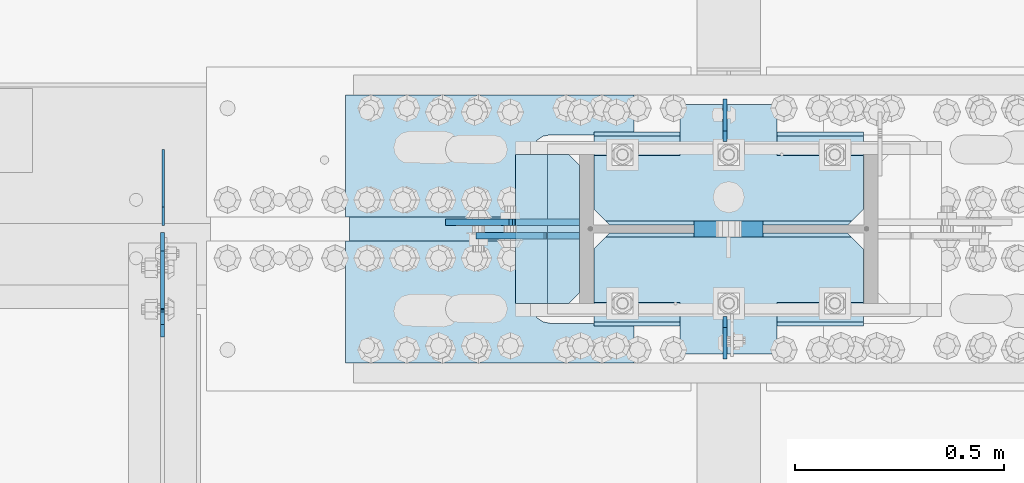
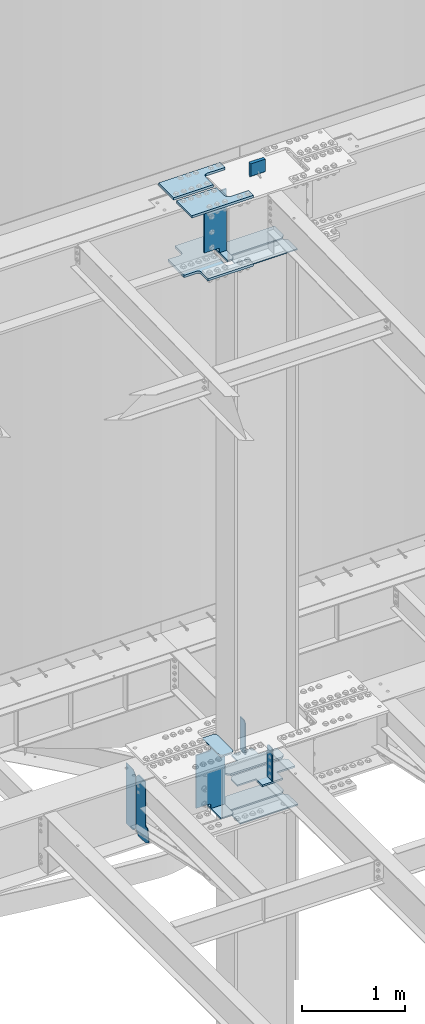
# One storey, part 1625 of 1763: 19 plates, 5 elements without a shape of their own.
"""IFC2X3 building model written with IfcOpenShell, lengths in millimetres."""

from ifc_helpers import new_model, si_unit, frame, origin_with_axes, place, context, subcontext, project, spatial, faceted_brep, material, type_object, element, aggregate, save


model = new_model("IFC2X3")

# Units and contexts
model_context = context("Model", 3, precision=1e-05, world=origin_with_axes())
body_context = subcontext(model_context, "Body", "Model", "MODEL_VIEW")
ifc_project = project(units=[si_unit("LENGTHUNIT", "METRE", prefix="MILLI"), si_unit("AREAUNIT", "SQUARE_METRE"), si_unit("VOLUMEUNIT", "CUBIC_METRE"), si_unit("MASSUNIT", "GRAM", prefix="KILO"), si_unit("TIMEUNIT", "SECOND"), si_unit("PLANEANGLEUNIT", "RADIAN"), si_unit("SOLIDANGLEUNIT", "STERADIAN"), si_unit("THERMODYNAMICTEMPERATUREUNIT", "DEGREE_CELSIUS"), si_unit("LUMINOUSINTENSITYUNIT", "LUMEN")], contexts=[model_context])

# Site, building, storey
site_placement = place(None, origin_with_axes())
site = spatial("IfcSite", under=ifc_project, at=site_placement, CompositionType="ELEMENT")
building_placement = place(site_placement, origin_with_axes())
building = spatial("IfcBuilding", under=site, at=building_placement, Name="Undefined", CompositionType="ELEMENT")
storey_placement = place(building_placement, origin_with_axes())
storey = spatial("IfcBuildingStorey", under=building, at=storey_placement, Name="Undefined", CompositionType="ELEMENT", Elevation=0.0)

# Assembly, plates
assembly_1_placement = place(storey_placement, origin_with_axes())
assembly_1 = element("IfcElementAssembly", 1, at=assembly_1_placement, inside=storey, Name="COLUMN", AssemblyPlace="NOTDEFINED", PredefinedType="RIGID_FRAME")
ifc_material_1 = material(Name="STEEL/A572-GR.50")
plate_type_1 = type_object("IfcPlateType", PredefinedType="NOTDEFINED")
plate_1_placement = place(assembly_1_placement, frame((-49411.1685236983, 51911.25, 5165.725), z_axis=(0.0, -1.0, 0.0), x_axis=(0.0, 0.0, -1.0)))
plate_1 = element("IfcPlate", 2, at=plate_1_placement, type_object=plate_type_1, material=ifc_material_1, Name="PLATE", context=body_context, shape_type="Brep", body=[
    faceted_brep([(25.3999996185303, -4.76250000000073, 0.0), (0.0, -4.76250000000073, 25.3999996185303), (0.0, 4.76250000000073, 25.3999996185303), (25.3999996185303, 4.76250000000073, 0.0), (1.45519152283669e-11, -4.76250000000448, 101.60001373291), (390.524993896484, -4.76249999999709, 101.599998474121), (390.524993896484, 4.76249999999709, 101.599998474121), (0.0, 4.76250000000243, 101.60001373291), (390.524993896484, -4.76249999999709, 0.0), (390.524993896484, 4.76249999999709, 0.0)], [[[0, 1, 2, 3]], [[4, 5, 6, 7]], [[5, 8, 9, 6]], [[9, 8, 0, 3]], [[7, 6, 9, 3, 2]], [[4, 7, 2, 1]], [[8, 5, 4, 1, 0]]]),
])
plate_2_placement = place(assembly_1_placement, frame((-49411.1685236984, 52330.35, 5165.725), z_axis=(0.0, 1.0, 0.0), x_axis=(0.0, 0.0, -1.0)))
plate_2 = element("IfcPlate", 3, at=plate_2_placement, type_object=plate_type_1, material=ifc_material_1, Name="PLATE", context=body_context, shape_type="Brep", body=[
    faceted_brep([(25.3999996185303, -4.76250000000073, 0.0), (0.0, -4.76250000000073, 25.3999996185303), (0.0, 4.76250000000073, 25.3999996185303), (25.3999996185303, 4.76250000000073, 0.0), (1.45519152283669e-11, -4.76250000000448, 101.60001373291), (390.524993896484, -4.76249999999709, 101.599998474121), (390.524993896484, 4.76249999999709, 101.599998474121), (0.0, 4.76250000000243, 101.60001373291), (390.524993896484, -4.76249999999709, 0.0), (390.524993896484, 4.76249999999709, 0.0)], [[[0, 1, 2, 3]], [[4, 5, 6, 7]], [[5, 8, 9, 6]], [[9, 8, 0, 3]], [[7, 6, 9, 3, 2]], [[4, 7, 2, 1]], [[8, 5, 4, 1, 0]]]),
])

# Assembly, plate
assembly_2_placement = place(storey_placement, origin_with_axes())
assembly_2 = element("IfcElementAssembly", 4, at=assembly_2_placement, inside=storey, Name="BEAM", AssemblyPlace="NOTDEFINED", PredefinedType="RIGID_FRAME")
ifc_material_2 = material(Name="STEEL/A36")
plate_type_2 = type_object("IfcPlateType", PredefinedType="NOTDEFINED")
plate_3_placement = place(assembly_2_placement, frame((-50754.987273746, 52128.7375, 4448.175), z_axis=(0.0, 0.0, 1.0), x_axis=(0.0, 1.0, 0.0)))
plate_3 = element("IfcPlate", 5, at=plate_3_placement, type_object=plate_type_2, material=ifc_material_2, Name="PLATE", context=body_context, shape_type="Brep", body=[
    faceted_brep([(0.0, -3.17500000000291, 44.4500000000007), (0.0, -3.17500000000291, 673.099987030029), (0.0, 3.17500000000291, 673.099987030029), (0.0, 3.17500000000291, 44.4500000000007), (44.4500007629395, -3.17500000000291, 717.549987792969), (44.4500007629395, 3.17500000000291, 717.549987792969), (182.5625, -3.17500000000291, 717.549987792969), (182.5625, 3.17500000000291, 717.549987792969), (182.5625, -3.17500000000291, 0.0), (182.5625, 3.17500000000291, 0.0), (44.4500007629395, -3.17500000000291, 0.0), (44.4500007629395, 3.17500000000291, 0.0)], [[[0, 1, 2, 3]], [[1, 4, 5, 2]], [[4, 6, 7, 5]], [[6, 8, 9, 7]], [[8, 10, 11, 9]], [[10, 0, 3, 11]], [[5, 7, 9, 11, 3, 2]], [[10, 8, 6, 4, 1, 0]]]),
])

# Plate
ifc_material_3 = material(Name="STEEL/A572-50")
plate_type_3 = type_object("IfcPlateType", PredefinedType="NOTDEFINED")
plate_4_placement = place(assembly_1_placement, frame((-49912.0247736984, 52298.6, 4427.5375), z_axis=(1.0, 0.0, 0.0), x_axis=(0.0, -1.0, 0.0)))
plate_4 = element("IfcPlate", 6, at=plate_4_placement, type_object=plate_type_3, material=ifc_material_3, Name="PLATE", context=body_context, shape_type="Brep", body=[
    faceted_brep([(-7.27595761418343e-12, -7.9375, 0.0), (0.0, -7.9375, 126.999994277954), (0.0, 7.9375, 126.999994277954), (-7.27595761418343e-12, 7.9375, 0.0), (25.3999996185303, -7.9375, 152.399993896484), (25.3999996185303, 7.9375, 152.399993896484), (330.200006484985, -7.9375, 152.399993896484), (330.200006484985, 7.9375, 152.399993896484), (355.600006103516, -7.9375, 126.999994277954), (355.600006103516, 7.9375, 126.999994277954), (355.600006103516, -7.9375, 0.0), (355.600006103516, 7.9375, 0.0)], [[[0, 1, 2, 3]], [[1, 4, 5, 2]], [[4, 6, 7, 5]], [[6, 8, 9, 7]], [[8, 10, 11, 9]], [[10, 0, 3, 11]], [[5, 7, 9, 11, 3, 2]], [[10, 8, 6, 4, 1, 0]]]),
])

plate_5_placement = place(assembly_1_placement, frame((-49912.0247736984, 52298.6, 5157.7875), z_axis=(1.0, 0.0, 0.0), x_axis=(0.0, -1.0, 0.0)))
plate_5 = element("IfcPlate", 7, at=plate_5_placement, type_object=plate_type_3, material=ifc_material_3, Name="PLATE", context=body_context, shape_type="Brep", body=[
    faceted_brep([(-7.27595761418343e-12, -7.9375, 0.0), (0.0, -7.9375, 126.999994277954), (0.0, 7.9375, 126.999994277954), (-7.27595761418343e-12, 7.9375, 0.0), (25.3999996185303, -7.9375, 152.399993896484), (25.3999996185303, 7.9375, 152.399993896484), (330.200006484985, -7.9375, 152.399993896484), (330.200006484985, 7.9375, 152.399993896484), (355.600006103516, -7.9375, 126.999994277954), (355.600006103516, 7.9375, 126.999994277954), (355.600006103516, -7.9375, 0.0), (355.600006103516, 7.9375, 0.0)], [[[0, 1, 2, 3]], [[1, 4, 5, 2]], [[4, 6, 7, 5]], [[6, 8, 9, 7]], [[8, 10, 11, 9]], [[10, 0, 3, 11]], [[5, 7, 9, 11, 3, 2]], [[10, 8, 6, 4, 1, 0]]]),
])

plate_type_4 = type_object("IfcPlateType", PredefinedType="NOTDEFINED")
plate_6_placement = place(assembly_1_placement, frame((-49724.6997736983, 51889.025, 4335.4625), z_axis=(1.0, 0.0, 0.0), x_axis=(0.0, 1.0, 0.0)))
plate_6 = element("IfcPlate", 8, at=plate_6_placement, type_object=plate_type_4, material=ifc_material_3, Name="HORIZONTAL SHEAR PLAT", context=body_context, shape_type="Brep", body=[
    faceted_brep([(-7.27595761418343e-12, -7.9375, 0.0), (0.0, -7.9375, 644.524963378906), (0.0, 7.9375, 644.524963378906), (-7.27595761418343e-12, 7.9375, 0.0), (184.150001525879, -7.9375, 644.524963378906), (184.150001525879, 7.9375, 644.524963378906), (222.25, -7.9375, 606.424964904785), (222.25, 7.9375, 606.424964904785), (222.25, -7.9375, 38.0999984741211), (222.25, 7.9375, 38.0999984741211), (184.150001525879, -7.9375, 0.0), (184.150001525879, 7.9375, 0.0)], [[[0, 1, 2, 3]], [[1, 4, 5, 2]], [[4, 6, 7, 5]], [[6, 8, 9, 7]], [[8, 10, 11, 9]], [[10, 0, 3, 11]], [[5, 7, 9, 11, 3, 2]], [[10, 8, 6, 4, 1, 0]]]),
])

plate_7_placement = place(assembly_1_placement, frame((-49724.6997736983, 52352.575, 4335.4625), z_axis=(1.0, 0.0, 0.0), x_axis=(0.0, -1.0, 0.0)))
plate_7 = element("IfcPlate", 9, at=plate_7_placement, type_object=plate_type_4, material=ifc_material_3, Name="HORIZONTAL SHEAR PLAT", context=body_context, shape_type="Brep", body=[
    faceted_brep([(-7.27595761418343e-12, -7.9375, 0.0), (0.0, -7.9375, 644.524963378906), (0.0, 7.9375, 644.524963378906), (-7.27595761418343e-12, 7.9375, 0.0), (184.150001525879, -7.9375, 644.524963378906), (184.150001525879, 7.9375, 644.524963378906), (222.25, -7.9375, 606.424964904785), (222.25, 7.9375, 606.424964904785), (222.25, -7.9375, 38.0999984741211), (222.25, 7.9375, 38.0999984741211), (184.150001525879, -7.9375, 0.0), (184.150001525879, 7.9375, 0.0)], [[[0, 1, 2, 3]], [[1, 4, 5, 2]], [[4, 6, 7, 5]], [[6, 8, 9, 7]], [[8, 10, 11, 9]], [[10, 0, 3, 11]], [[5, 7, 9, 11, 3, 2]], [[10, 8, 6, 4, 1, 0]]]),
])

plate_type_5 = type_object("IfcPlateType", PredefinedType="NOTDEFINED")
plate_8_placement = place(assembly_1_placement, frame((-49080.1747736984, 51898.55, 10887.0749917654), z_axis=(-1.0, 0.0, 0.0), x_axis=(0.0, 1.0, 0.0)))
plate_8 = element("IfcPlate", 10, at=plate_8_placement, type_object=plate_type_5, material=ifc_material_3, Name="PLATE", context=body_context, shape_type="Brep", body=[
    faceted_brep([(0.0, -6.34999999999491, 1.45519152283669e-11), (0.0, -6.35000000000036, 644.525024414062), (0.0, 6.35000000000036, 644.525024414062), (0.0, 6.34999999999491, -2.91038304567337e-11), (174.625007629395, -6.35000000000036, 644.525024414062), (174.625007629395, 6.35000000000036, 644.525024414062), (212.725006103516, -6.35000000000036, 606.425025939941), (212.725006103516, 6.35000000000036, 606.425025939941), (212.725006103516, -6.35000000000036, 38.0999984741211), (212.725006103516, 6.35000000000036, 38.0999984741211), (174.625007629395, -6.35000000000036, 0.0), (174.625007629395, 6.35000000000036, 0.0)], [[[0, 1, 2, 3]], [[1, 4, 5, 2]], [[4, 6, 7, 5]], [[6, 8, 9, 7]], [[8, 10, 11, 9]], [[10, 0, 3, 11]], [[5, 7, 9, 11, 3, 2]], [[10, 8, 6, 4, 1, 0]]]),
])

plate_9_placement = place(assembly_1_placement, frame((-49080.1747736984, 52130.325, 10887.0749917654), z_axis=(-1.0, 0.0, 0.0), x_axis=(0.0, 1.0, 0.0)))
plate_9 = element("IfcPlate", 11, at=plate_9_placement, type_object=plate_type_5, material=ifc_material_3, Name="PLATE", context=body_context, shape_type="Brep", body=[
    faceted_brep([(0.0, -6.34999999999854, 38.0999984741211), (0.0, -6.35000000000036, 606.425025939941), (0.0, 6.35000000000036, 606.425025939941), (0.0, 6.34999999999854, 38.0999984741211), (38.0999984741211, -6.35000000000036, 644.525024414062), (38.0999984741211, 6.35000000000036, 644.525024414062), (212.725006103516, -6.35000000000036, 644.525024414062), (212.725006103516, 6.35000000000036, 644.525024414062), (212.725006103516, -6.35000000000036, 0.0), (212.725006103516, 6.35000000000036, 0.0), (38.0999984741211, -6.34999999999854, 0.0), (38.0999984741211, 6.34999999999854, 0.0)], [[[0, 1, 2, 3]], [[1, 4, 5, 2]], [[4, 6, 7, 5]], [[6, 8, 9, 7]], [[8, 10, 11, 9]], [[10, 0, 3, 11]], [[5, 7, 9, 11, 3, 2]], [[10, 8, 6, 4, 1, 0]]]),
])

plate_type_6 = type_object("IfcPlateType", PredefinedType="NOTDEFINED")
plate_10_placement = place(assembly_1_placement, frame((-49080.1747736984, 51822.35, 4749.8), z_axis=(-1.0, 0.0, 0.0), x_axis=(0.0, 1.0, 0.0)))
plate_10 = element("IfcPlate", 12, at=plate_10_placement, type_object=plate_type_6, material=ifc_material_3, Name="PLATE", context=body_context, shape_type="Brep", body=[
    faceted_brep([(288.924987792969, -7.65116965339985e-07, 606.425025939941), (279.399988558085, -9.52499999999964, 615.950025174825), (279.399988558085, -9.52499999999964, 28.5749992392375), (288.924987792969, -7.65116965339985e-07, 38.0999984741211), (250.824989318848, -9.52499999999964, 644.525024414062), (250.824989318848, 9.52499999999964, 644.525024414062), (122.237487792991, 9.52499999999964, 644.525024414062), (122.237487792991, -9.52499999999964, 644.525015258769), (122.237487792983, 9.52499999999964, 438.14999999998), (122.237487792983, -9.52499999999964, 438.14999999998), (0.0, 9.52499999999964, 438.149991923026), (0.0, -9.52499999999964, 438.149991923026), (0.0, 9.52499999999964, 206.375007181632), (0.0, -9.52499999999964, 206.375007181632), (250.824989318848, 9.52499999999964, 0.0), (250.824989318848, -9.52499999999964, 0.0), (122.237487792998, -9.52499999999964, 0.0), (122.237487792998, 9.52499999999964, 0.0), (122.237487793005, -9.52499999999964, 206.375015258775), (122.237487793005, 9.52499999999964, 206.375015258775), (288.924987792969, 9.52499999999964, 606.425025939941), (288.924987792969, 9.52499999999964, 38.0999984741211)], [[[0, 1, 2, 3]], [[4, 5, 6, 7]], [[7, 6, 8, 9]], [[9, 8, 10, 11]], [[11, 10, 12, 13]], [[14, 15, 16, 17]], [[18, 19, 17, 16]], [[13, 12, 19, 18]], [[10, 8, 6, 5, 20, 21, 14, 17, 19, 12]], [[21, 20, 0, 3]], [[15, 14, 21, 3, 2]], [[4, 7, 9, 11, 13, 18, 16, 15, 2, 1]], [[20, 5, 4, 1, 0]]]),
])

plate_11_placement = place(assembly_1_placement, frame((-49080.1747736984, 52130.325, 4749.8), z_axis=(-1.0, 0.0, 0.0), x_axis=(0.0, 1.0, 0.0)))
plate_11 = element("IfcPlate", 13, at=plate_11_placement, type_object=plate_type_6, material=ifc_material_3, Name="PLATE", context=body_context, shape_type="Brep", body=[
    faceted_brep([(9.52499923488358, -9.52499999999964, 615.950025174825), (0.0, -7.65116965339985e-07, 606.425025939941), (0.0, 0.0, 38.0999984741211), (9.52499923488358, -9.52499999999964, 28.5749992392375), (288.924987792961, -9.52499999999964, 438.14999999998), (288.924987792969, 9.52499999999964, 438.14999999998), (166.687499999833, 9.52499999999964, 438.149991923055), (166.687499999833, -9.52499999999964, 438.149991923055), (288.924987792983, -9.52499999999964, 206.375015258775), (288.924987792969, 9.52499999999964, 206.375015258775), (38.0999984741211, -9.52500000000146, 0.0), (38.0999984741211, 9.52500000000146, 0.0), (166.6875, 9.52499999999964, 0.0), (166.6875, -9.52499999999964, 0.0), (166.687503076391, 9.52499999999964, 206.375007181618), (166.687503076391, -9.52499999999964, 206.375007181618), (0.0, 9.52500000000146, 38.0999984741211), (0.0, 9.52499999999964, 606.425025939941), (38.0999984741211, 9.52499999999964, 644.525024414062), (166.687503076224, 9.52499999999964, 644.525024414062), (166.687503076224, -9.52499999999964, 644.525024414062), (38.0999984741211, -9.52499999999964, 644.525024414062)], [[[0, 1, 2, 3]], [[4, 5, 6, 7]], [[5, 4, 8, 9]], [[10, 11, 12, 13]], [[13, 12, 14, 15]], [[8, 15, 14, 9]], [[12, 11, 16, 17, 18, 19, 6, 5, 9, 14]], [[20, 7, 6, 19]], [[18, 21, 20, 19]], [[10, 13, 15, 8, 4, 7, 20, 21, 0, 3]], [[16, 11, 10, 3, 2]], [[17, 16, 2, 1]], [[21, 18, 17, 1, 0]]]),
])

# Assembly, plate
assembly_3_placement = place(storey_placement, origin_with_axes())
assembly_3 = element("IfcElementAssembly", 14, at=assembly_3_placement, inside=storey, Name="PLATE", AssemblyPlace="NOTDEFINED", PredefinedType="RIGID_FRAME")
plate_type_7 = type_object("IfcPlateType", PredefinedType="NOTDEFINED")
plate_12_placement = place(assembly_3_placement, frame((-49629.4497736983, 52441.4750002128, 10955.3374917654), z_axis=(0.0, -1.0, 0.0), x_axis=(-1.0, 0.0, 0.0)))
plate_12 = element("IfcPlate", 15, at=plate_12_placement, type_object=plate_type_7, material=ifc_material_3, Name="PLATE", context=body_context, shape_type="Brep", body=[
    faceted_brep([(0.0, -14.2875000000058, 0.0), (0.0, -14.2875000000004, 95.25), (0.0, 14.2875000000004, 95.25), (0.0, 14.2875000000058, 0.0), (209.550006866455, -14.2875000000004, 95.25), (209.550006866455, 14.2875000000004, 95.25), (220.342425159237, -14.2875000000004, 96.9593511310522), (220.342425159237, 14.2875000000004, 96.9593511310522), (230.078406354325, -14.2875000000004, 101.920081325748), (230.078406354325, 14.2875000000004, 101.920081325748), (237.804924777767, -14.2875000000004, 109.646599749191), (237.804924777767, 14.2875000000004, 109.646599749191), (242.765654972463, -14.2875000000004, 119.382580944279), (242.765654972463, 14.2875000000004, 119.382580944279), (244.475006103516, -14.2875000000004, 130.174999237061), (244.475006103516, 14.2875000000004, 130.174999237061), (244.475006103516, -14.2875000000004, 511.174976348877), (244.475006103516, 14.2875000000004, 511.174976348877), (242.765654972463, -14.2875000000004, 521.967394641659), (242.765654972463, 14.2875000000004, 521.967394641659), (237.804924777767, -14.2875000000004, 531.703375836747), (237.804924777767, 14.2875000000004, 531.703375836747), (230.078406354325, -14.2875000000004, 539.429894260189), (230.078406354325, 14.2875000000004, 539.429894260189), (220.342425159237, -14.2875000000004, 544.390624454885), (220.342425159237, 14.2875000000004, 544.390624454885), (209.550006866455, -14.2875000000004, 546.099975585938), (209.550006866455, 14.2875000000004, 546.099975585938), (0.0, -14.2875000000004, 546.099975585938), (0.0, 14.2875000000004, 546.099975585938), (0.0, -14.2875000000004, 641.349975585938), (0.0, 14.2875000000004, 641.349975585938), (508.0, -14.2875000000004, 641.349975585938), (508.0, 14.2875000000004, 641.349975585938), (508.0, -14.2875000000004, 511.174999237061), (508.0, 14.2875000000004, 511.174999237061), (509.709351131052, -14.2875000000004, 500.382580944279), (509.709351131052, 14.2875000000004, 500.382580944279), (514.670081325748, -14.2875000000004, 490.646599749191), (514.670081325748, 14.2875000000004, 490.646599749191), (522.396599749191, -14.2875000000004, 482.920081325748), (522.396599749191, 14.2875000000004, 482.920081325748), (532.132580944279, -14.2875000000004, 477.959351131052), (532.132580944279, 14.2875000000004, 477.959351131052), (542.924999237061, -14.2875000000004, 476.25), (542.924999237061, 14.2875000000004, 476.25), (679.450012207031, -14.2875000000004, 476.25), (679.450012207031, 14.2875000000004, 476.25), (679.450012207031, -14.2875000000004, 165.100006103516), (679.450012207031, 14.2875000000004, 165.100006103516), (542.924999237061, -14.2875000000004, 165.100006103516), (542.924999237061, 14.2875000000004, 165.100006103516), (532.132580944279, -14.2875000000004, 163.390654972463), (532.132580944279, 14.2875000000004, 163.390654972463), (522.396599749191, -14.2875000000004, 158.429924777767), (522.396599749191, 14.2875000000004, 158.429924777767), (514.670081325748, -14.2875000000004, 150.703406354325), (514.670081325748, 14.2875000000004, 150.703406354325), (509.709351131052, -14.2875000000004, 140.967425159237), (509.709351131052, 14.2875000000004, 140.967425159237), (508.0, -14.2875000000004, 130.175006866455), (508.0, 14.2875000000004, 130.175006866455), (508.0, -14.2875000000004, 0.0), (508.0, 14.2875000000004, 0.0)], [[[0, 1, 2, 3]], [[1, 4, 5, 2]], [[4, 6, 7, 5]], [[6, 8, 9, 7]], [[8, 10, 11, 9]], [[10, 12, 13, 11]], [[12, 14, 15, 13]], [[14, 16, 17, 15]], [[16, 18, 19, 17]], [[18, 20, 21, 19]], [[20, 22, 23, 21]], [[22, 24, 25, 23]], [[24, 26, 27, 25]], [[26, 28, 29, 27]], [[28, 30, 31, 29]], [[30, 32, 33, 31]], [[32, 34, 35, 33]], [[34, 36, 37, 35]], [[36, 38, 39, 37]], [[38, 40, 41, 39]], [[40, 42, 43, 41]], [[42, 44, 45, 43]], [[44, 46, 47, 45]], [[46, 48, 49, 47]], [[48, 50, 51, 49]], [[50, 52, 53, 51]], [[52, 54, 55, 53]], [[54, 56, 57, 55]], [[56, 58, 59, 57]], [[58, 60, 61, 59]], [[60, 62, 63, 61]], [[62, 0, 3, 63]], [[5, 7, 9, 11, 13, 15, 17, 19, 21, 23, 25, 27, 29, 31, 33, 35, 37, 39, 41, 43, 45, 47, 49, 51, 53, 55, 57, 59, 61, 63, 3, 2]], [[62, 60, 58, 56, 54, 52, 50, 48, 46, 44, 42, 40, 38, 36, 34, 32, 30, 28, 26, 24, 22, 20, 18, 16, 14, 12, 10, 8, 6, 4, 1, 0]]]),
])
aggregate(assembly_3, [plate_12])

assembly_4_placement = place(storey_placement, origin_with_axes())
assembly_4 = element("IfcElementAssembly", 16, at=assembly_4_placement, inside=storey, Name="TOP PLATE", AssemblyPlace="NOTDEFINED", PredefinedType="RIGID_FRAME")
plate_type_8 = type_object("IfcPlateType", PredefinedType="NOTDEFINED")
plate_13_placement = place(assembly_4_placement, frame((-50318.4247736983, 52149.3750002128, 11761.7874917654), z_axis=(0.0, 1.0, 0.0), x_axis=(1.0, 0.0, 0.0)))
plate_13 = element("IfcPlate", 17, at=plate_13_placement, type_object=plate_type_8, material=ifc_material_3, Name="TOP PLATE", context=body_context, shape_type="Brep", body=[
    faceted_brep([(0.0, -14.2875000000058, 0.0), (0.0, -14.2875000000004, 292.100006103516), (0.0, 14.2875000000004, 292.100006103516), (0.0, 14.2875000000058, 0.0), (688.974975585938, -14.2875000000004, 292.100006103516), (688.974975585938, 14.2875000000004, 292.100006103516), (688.974975585938, -14.2875000000004, 196.850006103516), (688.974975585938, 14.2875000000004, 196.850006103516), (488.950000762939, -14.2875000000004, 196.850006103516), (488.950000762939, 14.2875000000004, 196.850006103516), (471.939721902345, -14.2875000000004, 193.466451265565), (471.939721902345, 14.2875000000004, 193.466451265565), (457.519103799721, -14.2875000000004, 183.830902303795), (457.519103799721, 14.2875000000004, 183.830902303795), (447.88355483795, -14.2875000000004, 169.410284201171), (447.88355483795, 14.2875000000004, 169.410284201171), (444.5, -14.2875000000004, 152.400005340576), (444.5, 14.2875000000004, 152.400005340576), (444.5, -14.2875000000004, 0.0), (444.5, 14.2875000000004, 0.0)], [[[0, 1, 2, 3]], [[1, 4, 5, 2]], [[4, 6, 7, 5]], [[6, 8, 9, 7]], [[8, 10, 11, 9]], [[10, 12, 13, 11]], [[12, 14, 15, 13]], [[14, 16, 17, 15]], [[16, 18, 19, 17]], [[18, 0, 3, 19]], [[5, 7, 9, 11, 13, 15, 17, 19, 3, 2]], [[18, 16, 14, 12, 10, 8, 6, 4, 1, 0]]]),
])
aggregate(assembly_4, [plate_13])

assembly_5_placement = place(storey_placement, origin_with_axes())
assembly_5 = element("IfcElementAssembly", 18, at=assembly_5_placement, inside=storey, Name="TOP PLATE", AssemblyPlace="NOTDEFINED", PredefinedType="RIGID_FRAME")
plate_14_placement = place(assembly_5_placement, frame((-49873.9247736983, 52092.2250002128, 11761.7874917654), z_axis=(0.0, -1.0, 0.0), x_axis=(-1.0, 0.0, 0.0)))
plate_14 = element("IfcPlate", 19, at=plate_14_placement, type_object=plate_type_8, material=ifc_material_3, Name="TOP PLATE", context=body_context, shape_type="Brep", body=[
    faceted_brep([(0.0, -14.2875000000058, 0.0), (0.0, -14.2875000000004, 152.400001525879), (0.0, 14.2875000000004, 152.400001525879), (0.0, 14.2875000000058, 0.0), (-3.38355483795021, -14.2875000000004, 169.410284201171), (-3.38355483795021, 14.2875000000004, 169.410284201171), (-13.0191037997211, -14.2875000000004, 183.830902303795), (-13.0191037997211, 14.2875000000004, 183.830902303795), (-27.4397219023449, -14.2875000000004, 193.466451265565), (-27.4397219023449, 14.2875000000004, 193.466451265565), (-44.4500007629395, -14.2875000000004, 196.850006103516), (-44.4500007629395, 14.2875000000004, 196.850006103516), (-244.475006103516, -14.2875000000004, 196.850006103516), (-244.475006103516, 14.2875000000004, 196.850006103516), (-244.475006103516, -14.2875000000004, 292.100006103516), (-244.475006103516, 14.2875000000004, 292.100006103516), (444.5, -14.2875000000004, 292.100006103516), (444.5, 14.2875000000004, 292.100006103516), (444.5, -14.2875000000004, 0.0), (444.5, 14.2875000000004, 0.0)], [[[0, 1, 2, 3]], [[1, 4, 5, 2]], [[4, 6, 7, 5]], [[6, 8, 9, 7]], [[8, 10, 11, 9]], [[10, 12, 13, 11]], [[12, 14, 15, 13]], [[14, 16, 17, 15]], [[16, 18, 19, 17]], [[18, 0, 3, 19]], [[5, 7, 9, 11, 13, 15, 17, 19, 3, 2]], [[18, 16, 14, 12, 10, 8, 6, 4, 1, 0]]]),
])
aggregate(assembly_5, [plate_14])

# Plate
plate_type_9 = type_object("IfcPlateType", PredefinedType="NOTDEFINED")
plate_15_placement = place(assembly_1_placement, frame((-49759.6247736983, 51943.0, 10980.7374917654), z_axis=(-1.0, 0.0, 0.0), x_axis=(0.0, 1.0, 0.0)))
plate_15 = element("IfcPlate", 20, at=plate_15_placement, type_object=plate_type_9, material=ifc_material_3, Name="BRIDGE PLATE", context=body_context, shape_type="Brep", body=[
    faceted_brep([(0.0, -11.1124999999993, 25.3999996185303), (0.0, -11.1124999999993, 76.1999969482422), (0.0, 11.1124999999993, 76.1999969482422), (0.0, 11.1124999999993, 25.3999996185303), (355.600006103516, -11.1124999999993, 76.1999969482422), (355.600006103516, 11.1124999999993, 76.1999969482422), (355.600006103516, -11.1124999999993, 25.3999996185303), (355.600006103516, 11.1124999999993, 25.3999996185303), (330.200006484985, -11.1124999999993, 0.0), (330.200006484985, 11.1124999999993, 0.0), (25.3999996185303, -11.1124999999993, 0.0), (25.3999996185303, 11.1124999999993, 0.0)], [[[0, 1, 2, 3]], [[1, 4, 5, 2]], [[4, 6, 7, 5]], [[6, 8, 9, 7]], [[8, 10, 11, 9]], [[10, 0, 3, 11]], [[5, 7, 9, 11, 3, 2]], [[10, 8, 6, 4, 1, 0]]]),
])

plate_type_10 = type_object("IfcPlateType", PredefinedType="NOTDEFINED")
plate_16_placement = place(assembly_1_placement, frame((-50007.2747736983, 52104.9250002128, 11045.8249917654), z_axis=(1.0, 0.0, 0.0), x_axis=(0.0, 0.0, 1.0)))
plate_16 = element("IfcPlate", 21, at=plate_16_placement, type_object=plate_type_10, material=ifc_material_3, Name="SHEAR TAB", context=body_context, shape_type="Brep", body=[
    faceted_brep([(-7.27595761418343e-12, -7.9375, 0.0), (0.0, -7.9375, 158.749997138977), (0.0, 7.9375, 158.749997138977), (-7.27595761418343e-12, 7.9375, 0.0), (-0.966729922587547, -7.9375, 163.610076657023), (-0.966729922587547, 7.9375, 163.610076657023), (-3.71974382306507, -7.9375, 167.730253125177), (-3.71974382306507, 7.9375, 167.730253125177), (-7.83992029121873, -7.9375, 170.483267025651), (-7.83992029121873, 7.9375, 170.483267025651), (-12.6999998092651, -7.9375, 171.449996948242), (-12.6999998092651, 7.9375, 171.449996948242), (-53.9749984741211, -7.9375, 171.449996948242), (-53.9749984741211, 7.9375, 171.449996948242), (-53.9749984741211, -7.9375, 247.649993896484), (-53.9749984741211, 7.9375, 247.649993896484), (671.512451171875, -7.9375, 247.649993896484), (671.512451171875, 7.9375, 247.649993896484), (671.512451171875, -7.9375, 171.449996948242), (671.512451171875, 7.9375, 171.449996948242), (638.174975395203, -7.9375, 171.449996948242), (638.174975395203, 7.9375, 171.449996948242), (633.314895877156, -7.9375, 170.483267025651), (633.314895877156, 7.9375, 170.483267025651), (629.194719409003, -7.9375, 167.730253125177), (629.194719409003, 7.9375, 167.730253125177), (626.441705508525, -7.9375, 163.610076657023), (626.441705508525, 7.9375, 163.610076657023), (625.474975585938, -7.9375, 158.749997138977), (625.474975585938, 7.9375, 158.749997138977), (625.474975585938, -7.9375, 0.0), (625.474975585938, 7.9375, 0.0)], [[[0, 1, 2, 3]], [[1, 4, 5, 2]], [[4, 6, 7, 5]], [[6, 8, 9, 7]], [[8, 10, 11, 9]], [[10, 12, 13, 11]], [[12, 14, 15, 13]], [[14, 16, 17, 15]], [[16, 18, 19, 17]], [[18, 20, 21, 19]], [[20, 22, 23, 21]], [[22, 24, 25, 23]], [[24, 26, 27, 25]], [[26, 28, 29, 27]], [[28, 30, 31, 29]], [[30, 0, 3, 31]], [[5, 7, 9, 11, 13, 15, 17, 19, 21, 23, 25, 27, 29, 31, 3, 2]], [[30, 28, 26, 24, 22, 20, 18, 16, 14, 12, 10, 8, 6, 4, 1, 0]]]),
])

plate_type_11 = type_object("IfcPlateType", PredefinedType="NOTDEFINED")
plate_17_placement = place(assembly_1_placement, frame((-50080.2997736984, 52136.675, 4435.475), z_axis=(1.0, 0.0, 0.0), x_axis=(0.0, 0.0, 1.0)))
plate_17 = element("IfcPlate", 22, at=plate_17_placement, type_object=plate_type_11, material=ifc_material_3, Name="SHEAR TAB", context=body_context, shape_type="Brep", body=[
    faceted_brep([(684.212475585938, -7.9375, 0.0), (684.212475585938, 7.9375, 0.0), (684.212475585938, 7.9375, 142.875009536743), (684.212475585938, -7.9375, 142.875009536743), (686.145935431114, 7.9375, 152.595168572821), (686.145935431114, -7.9375, 152.595168572821), (691.65196323207, 7.9375, 160.835521509129), (691.65196323207, -7.9375, 160.835521509129), (699.892316168377, 7.9375, 166.341549310091), (699.892316168377, -7.9375, 166.341549310091), (709.612475204468, 7.9375, 168.275009155273), (709.612475204468, -7.9375, 168.275009155273), (712.787475585938, -7.9375, 168.275009155273), (712.787475585938, 7.9375, 168.275009155273), (58.7375022888209, -7.9375, 142.875012588498), (58.7375022888209, 7.9375, 142.875012588498), (58.7375022888209, 7.9375, 0.0), (58.7375022888209, -7.9375, 0.0), (56.8040424436449, -7.9375, 152.595171624591), (56.8040424436449, 7.9375, 152.595171624591), (51.2980146426889, -7.9375, 160.835524560898), (51.2980146426889, 7.9375, 160.835524560898), (43.0576617063816, -7.9375, 166.341552361846), (43.0576617063816, 7.9375, 166.341552361846), (33.3375026702906, -7.9375, 168.275012207028), (33.3375026702906, 7.9375, 168.275012207028), (0.0, -7.9375, 168.275012207028), (0.0, 7.9375, 168.275012207028), (0.0, -7.9375, 320.674987792969), (0.0, 7.9375, 320.674987792969), (712.787475585938, -7.9375, 320.674987792969), (712.787475585938, 7.9375, 320.674987792969)], [[[0, 1, 2, 3]], [[3, 2, 4, 5]], [[5, 4, 6, 7]], [[7, 6, 8, 9]], [[9, 8, 10, 11]], [[12, 11, 10, 13]], [[14, 15, 16, 17]], [[18, 19, 15, 14]], [[20, 21, 19, 18]], [[22, 23, 21, 20]], [[24, 25, 23, 22]], [[26, 27, 25, 24]], [[28, 29, 27, 26]], [[28, 30, 31, 29]], [[31, 30, 12, 13]], [[8, 6, 4, 2, 1, 16, 15, 19, 21, 23, 25, 27, 29, 31, 13, 10]], [[17, 16, 1, 0]], [[30, 28, 26, 24, 22, 20, 18, 14, 17, 0, 3, 5, 7, 9, 11, 12]]]),
])

plate_type_12 = type_object("IfcPlateType", PredefinedType="NOTDEFINED")
plate_18_placement = place(assembly_2_placement, frame((-50756.574773746, 52112.8625, 4448.175), z_axis=(0.0, 0.0, 1.0), x_axis=(0.0, -1.0, 0.0)))
plate_18 = element("IfcPlate", 23, at=plate_18_placement, type_object=plate_type_12, material=ifc_material_2, Name="PLATE", context=body_context, shape_type="Brep", body=[
    faceted_brep([(-8.03411239758134e-08, -4.76249999999709, 44.4500007629395), (-1.21945049613714e-06, -4.76249999999709, 674.687450408936), (-1.21945049613714e-06, 4.76249999999709, 674.687450408936), (-8.03411239758134e-08, 4.76249999999709, 44.4500007629395), (44.4499994631478, -4.76249999999709, 719.137436311141), (44.4499994631478, 4.76249999999709, 719.137436311141), (182.5625, -4.76249999999709, 719.137390136719), (182.5625, 4.76249999999709, 719.137390136719), (182.5625, -4.76249999999709, 201.622897148132), (182.5625, 4.76249999999709, 201.622897148132), (183.529229922591, -4.76249999999709, 196.762817630087), (183.529229922591, 4.76249999999709, 196.762817630087), (186.282243823065, -4.76249999999709, 192.642641161933), (186.282243823065, 4.76249999999709, 192.642641161933), (190.402420291219, -4.76249999999709, 189.889627261455), (190.402420291219, 4.76249999999709, 189.889627261455), (195.262499809265, -4.76249999999709, 188.922897338867), (195.262499809265, 4.76249999999709, 188.922897338867), (219.799514770508, -4.76249999999709, 188.922897338867), (219.799514770508, 4.76249999999709, 188.922897338867), (250.737014770508, -4.76249999999709, 42.4546127319336), (250.737014770508, 4.76249999999709, 42.4546127319336), (182.5625, -4.76249999999709, -3.63797880709171e-12), (182.5625, 4.76249999999709, -3.63797880709171e-12), (44.4500007629395, -4.76249999999709, 0.0), (44.4500007629395, 4.76249999999709, 0.0)], [[[0, 1, 2, 3]], [[1, 4, 5, 2]], [[4, 6, 7, 5]], [[6, 8, 9, 7]], [[8, 10, 11, 9]], [[10, 12, 13, 11]], [[12, 14, 15, 13]], [[14, 16, 17, 15]], [[16, 18, 19, 17]], [[18, 20, 21, 19]], [[20, 22, 23, 21]], [[22, 24, 25, 23]], [[24, 0, 3, 25]], [[5, 7, 9, 11, 13, 15, 17, 19, 21, 23, 25, 3, 2]], [[24, 22, 20, 18, 16, 14, 12, 10, 8, 6, 4, 1, 0]]]),
])

aggregate(assembly_2, [plate_3, plate_18])

plate_type_13 = type_object("IfcPlateType", PredefinedType="NOTDEFINED")
plate_19_placement = place(assembly_1_placement, frame((-49319.8872721725, 52120.8, 11912.5999909009), z_axis=(0.0, 0.0, -1.0), x_axis=(-1.0, 0.0, 0.0)))
plate_19 = element("IfcPlate", 24, at=plate_19_placement, type_object=plate_type_13, material=ifc_material_3, Name="PLATE", context=body_context, shape_type="Brep", body=[
    faceted_brep([(0.0, 19.05, 146.049990844727), (-1.45519152283669e-11, 7.27595761418343e-12, 165.099990844727), (165.099990844727, 0.0, 165.099990844727), (165.099990844727, 19.05, 146.049990844727), (0.0, -19.05, 146.049990844727), (165.099990844727, -19.05, 146.049990844727), (0.0, 19.0500000000029, 0.0), (0.0, -19.0500000000029, 0.0), (165.10000190921, -19.0500000000029, 0.0), (165.10000190921, 19.0500000000029, 0.0)], [[[0, 1, 2, 3]], [[1, 4, 5, 2]], [[6, 7, 4, 1, 0]], [[5, 8, 9, 3, 2]], [[8, 7, 6, 9]], [[9, 6, 0, 3]], [[7, 8, 5, 4]]]),
])

aggregate(assembly_1, [plate_6, plate_7, plate_4, plate_5, plate_8, plate_9, plate_10, plate_11, plate_15, plate_16, plate_1, plate_2, plate_17, plate_19])

save(model, "model.ifc")
